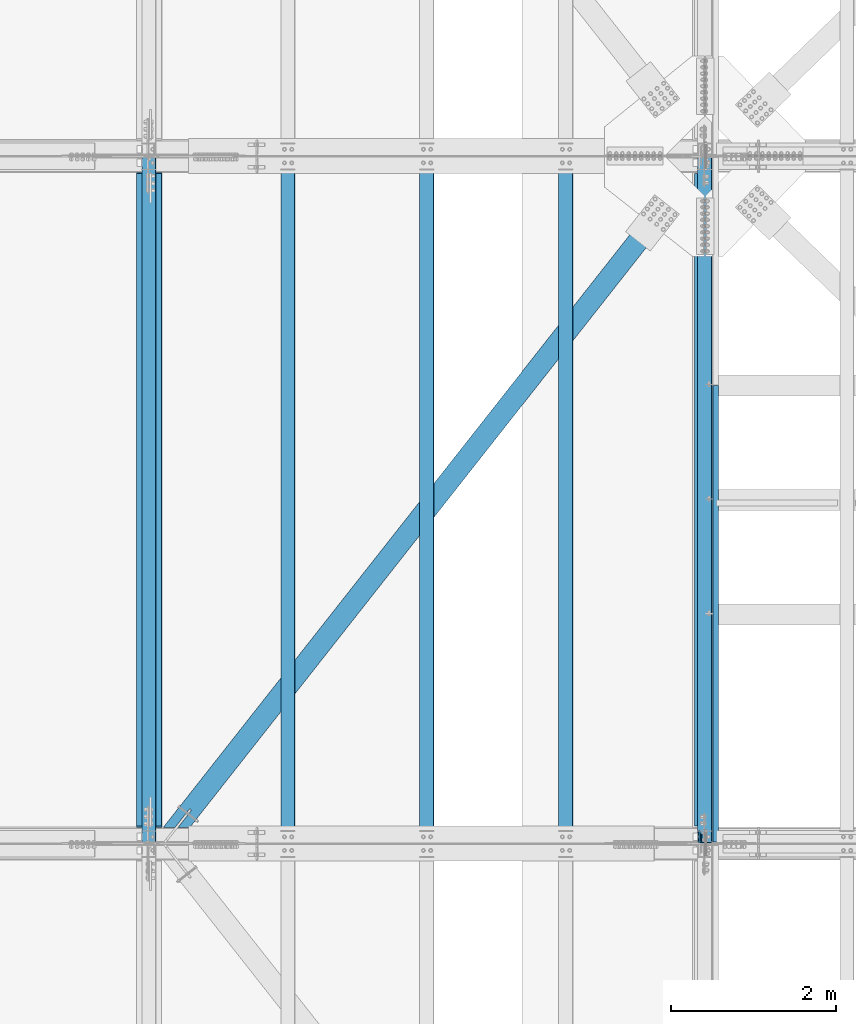
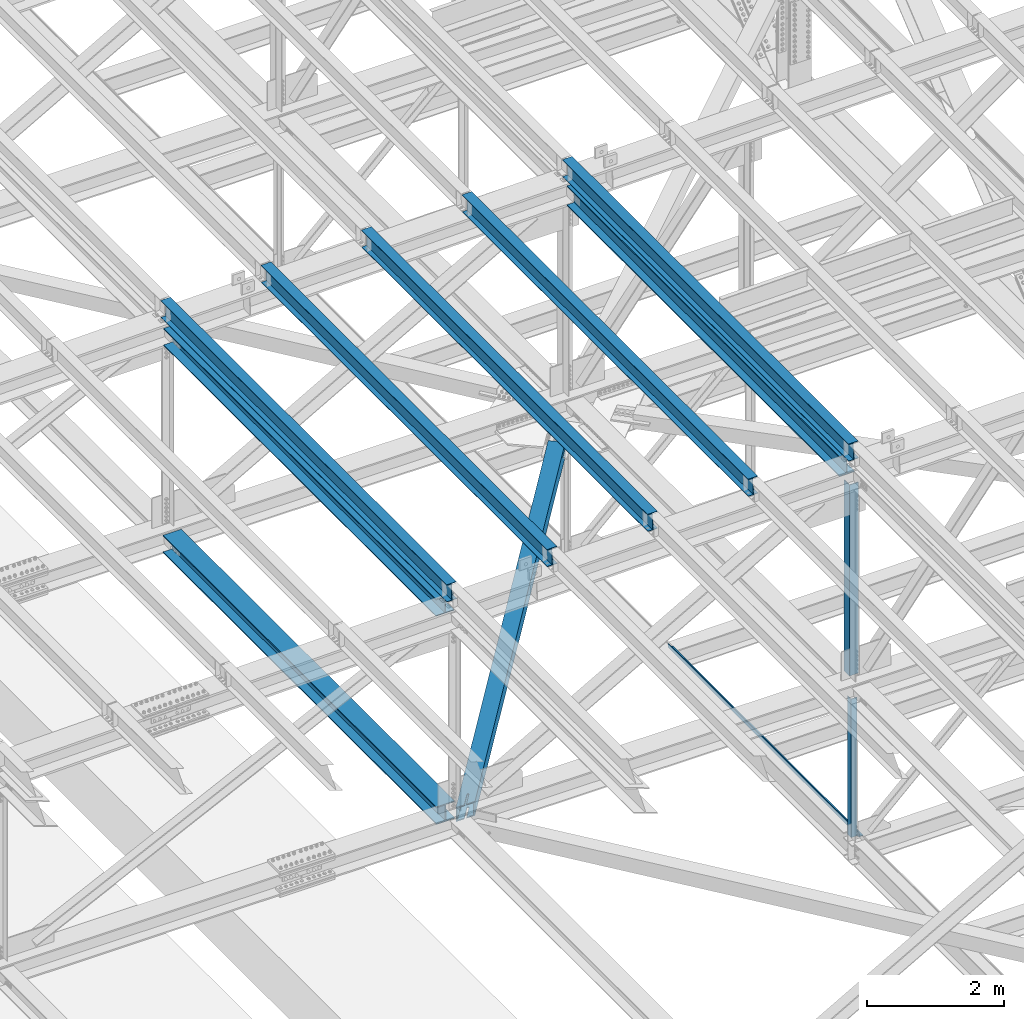
# One storey, part 1856 of 3843: 12 beams, 12 elements without a shape of their own.
"""IFC2X3 building model written with IfcOpenShell, lengths in millimetres."""

from ifc_helpers import new_model, si_unit, frame, origin_with_axes, place, context, subcontext, project, spatial, faceted_brep, material, type_object, element, aggregate, save


model = new_model("IFC2X3")

# Units and contexts
model_context = context("Model", 3, precision=1e-05, world=origin_with_axes())
body_context = subcontext(model_context, "Body", "Model", "MODEL_VIEW")
ifc_project = project(units=[si_unit("LENGTHUNIT", "METRE", prefix="MILLI"), si_unit("AREAUNIT", "SQUARE_METRE"), si_unit("VOLUMEUNIT", "CUBIC_METRE"), si_unit("MASSUNIT", "GRAM", prefix="KILO"), si_unit("TIMEUNIT", "SECOND"), si_unit("PLANEANGLEUNIT", "RADIAN"), si_unit("SOLIDANGLEUNIT", "STERADIAN"), si_unit("THERMODYNAMICTEMPERATUREUNIT", "DEGREE_CELSIUS"), si_unit("LUMINOUSINTENSITYUNIT", "LUMEN")], contexts=[model_context])

# Site, building, storey
site_placement = place(None, origin_with_axes())
site = spatial("IfcSite", under=ifc_project, at=site_placement, CompositionType="ELEMENT")
building_placement = place(site_placement, origin_with_axes())
building = spatial("IfcBuilding", under=site, at=building_placement, Name="Undefined", CompositionType="ELEMENT")
storey_placement = place(building_placement, origin_with_axes())
storey = spatial("IfcBuildingStorey", under=building, at=storey_placement, Name="Undefined", CompositionType="ELEMENT", Elevation=0.0)

# Assembly, beam
assembly_1_placement = place(storey_placement, origin_with_axes())
assembly_1 = element("IfcElementAssembly", 1, at=assembly_1_placement, inside=storey, Name="ANGLE", AssemblyPlace="NOTDEFINED", PredefinedType="RIGID_FRAME")
ifc_material_1 = material(Name="STEEL/A572-50")
beam_type_1 = type_object("IfcBeamType", Name="L4X4X3/8", PredefinedType="NOTDEFINED")
beam_1_placement = place(assembly_1_placement, frame((77012.7999999999, 50619.025, 42337.7414626822), z_axis=(0.0, 1.0, 0.0), x_axis=(0.0, 0.0, -1.0)))
beam_1 = element("IfcBeam", 2, at=beam_1_placement, type_object=beam_type_1, material=ifc_material_1, Name="ANGLE", ObjectType="L4X4X3/8", context=body_context, shape_type="Brep", body=[
    faceted_brep([(209.619479922985, 50.8000000000029, -50.8000000000029), (209.619479922985, 50.8000000000029, 50.8000000000029), (2671.51545346303, 50.8000000000029, 50.8000000000029), (2671.51545346303, 50.8000000000029, -50.8000000000029), (209.619479922985, 41.2749999999942, 50.8000000000029), (2671.51545346303, 41.2749999999942, 50.8000000000029), (209.619479922985, 41.2749999999942, -41.2750000000015), (2671.51545346303, 41.2749999999942, -41.2750000000015), (209.619479922985, -50.8000000000029, -41.2750000000015), (2671.51545346303, -50.8000000000029, -41.2750000000015), (209.619479922985, -50.8000000000029, -50.8000000000029), (2671.51545346303, -50.8000000000029, -50.8000000000029)], [[[0, 1, 2, 3]], [[1, 4, 5, 2]], [[4, 6, 7, 5]], [[6, 8, 9, 7]], [[8, 10, 11, 9]], [[10, 0, 3, 11]], [[5, 7, 9, 11, 3, 2]], [[10, 8, 6, 4, 1, 0]]]),
])
aggregate(assembly_1, [beam_1])

assembly_2_placement = place(storey_placement, origin_with_axes())
assembly_2 = element("IfcElementAssembly", 3, at=assembly_2_placement, inside=storey, Name="BEAM", AssemblyPlace="NOTDEFINED", PredefinedType="RIGID_FRAME")
ifc_material_2 = material(Name="STEEL/A992")
beam_type_2 = type_object("IfcBeamType", Name="W12X26", PredefinedType="NOTDEFINED")
beam_2_placement = place(assembly_2_placement, frame((77009.5092626681, 50558.6104205295, 46520.6173903341), z_axis=(-0.0211520975154853, -0.000575795999735418, 0.999776103550021), x_axis=(0.0, 0.999999834155183, 0.000575925000089143)))
beam_2 = element("IfcBeam", 4, at=beam_2_placement, type_object=beam_type_2, material=ifc_material_2, Name="BEAM", ObjectType="W12X26", context=body_context, shape_type="Brep", body=[
    faceted_brep([(12.6989964649474, 82.5499999998865, -155.574999999983), (12.7044809241561, 82.549999999901, -146.049999999967), (8343.90586255472, 82.5500000002794, -146.050000017567), (8343.90037809552, 82.5500000002648, -155.575000017569), (12.7054478725186, 3.17499999949359, -146.050000000199), (8343.90682950308, 3.17499999987194, -146.050000017793), (12.8736379546172, 3.17500000052678, 146.050000000163), (8344.07501958519, 3.17500000090513, 146.04999998257), (12.8726710062547, 82.5500000009342, 146.050000000396), (8344.07405263682, 82.5500000013126, 146.04999998281), (12.8781554654561, 82.5500000009633, 155.575000000412), (8344.07953709602, 82.5500000013417, 155.574999982811), (12.8801667180524, -82.549999999901, 155.574999999924), (8344.08154834861, -82.5499999995227, 155.574999982331), (12.874682258851, -82.5499999999302, 146.049999999916), (8344.07606388941, -82.5499999995518, 146.049999982315), (12.8737153104885, -3.17499999950815, 146.050000000148), (8344.07509694105, -3.17499999914435, 146.049999982555), (12.7055252283826, -3.17500000054133, -146.050000000221), (8343.90690685896, -3.17500000016298, -146.050000017814), (12.7064921767451, -82.5500000009488, -146.050000000454), (8343.90787380732, -82.5500000005704, -146.050000018047), (12.701007717551, -82.5500000009924, -155.575000000463), (8343.90238934811, -82.5500000006141, -155.575000018063)], [[[0, 1, 2, 3]], [[1, 4, 5, 2]], [[4, 6, 7, 5]], [[6, 8, 9, 7]], [[8, 10, 11, 9]], [[10, 12, 13, 11]], [[12, 14, 15, 13]], [[14, 16, 17, 15]], [[16, 18, 19, 17]], [[18, 20, 21, 19]], [[20, 22, 23, 21]], [[22, 0, 3, 23]], [[5, 7, 9, 11, 13, 15, 17, 19, 21, 23, 3, 2]], [[22, 20, 18, 16, 14, 12, 10, 8, 6, 4, 1, 0]]]),
])
aggregate(assembly_2, [beam_2])

assembly_3_placement = place(storey_placement, origin_with_axes())
assembly_3 = element("IfcElementAssembly", 5, at=assembly_3_placement, inside=storey, Name="BEAM", AssemblyPlace="NOTDEFINED", PredefinedType="RIGID_FRAME")
beam_3_placement = place(assembly_3_placement, frame((70253.109262286, 50558.6253514416, 46384.1035402932), z_axis=(-0.0211520984433592, -0.000479824000096415, 0.999776154196714), x_axis=(0.0, 0.999999884833111, 0.000479930999919957)))
beam_3 = element("IfcBeam", 6, at=beam_3_placement, type_object=beam_type_2, material=ifc_material_2, Name="BEAM", ObjectType="W12X26", context=body_context, shape_type="Brep", body=[
    faceted_brep([(12.6991634509395, 82.5499999998428, -155.574999999844), (12.7037337714428, 82.5499999998719, -146.049999999865), (8343.90469330046, 82.5500000003376, -146.050000022165), (8343.90012297995, 82.5500000002939, -155.575000022138), (12.7045395506648, 3.17499999943539, -146.049999999675), (8343.90549907969, 3.17499999990105, -146.050000021976), (12.8446960464062, 3.17500000059954, 146.049999999588), (8344.04565557543, 3.1750000010652, 146.049999977295), (12.8438902671915, 82.5500000010361, 146.049999999399), (8344.04484979621, 82.5500000015018, 146.049999977098), (12.848460587702, 82.5500000010943, 155.574999999371), (8344.04942011672, 82.5500000015454, 155.574999977071), (12.8501366084674, -82.5499999998428, 155.574999999772), (8344.05109613749, -82.5499999993917, 155.574999977478), (12.8455662879569, -82.5499999998719, 146.049999999792), (8344.04652581698, -82.5499999994208, 146.049999977491), (12.8447605087349, -3.17499999943539, 146.049999999603), (8344.04572003776, -3.17499999898428, 146.049999977302), (12.7046040130008, -3.17500000061409, -146.049999999661), (8343.90556354202, -3.17500000014843, -146.050000021954), (12.7054097922155, -82.5500000010506, -146.049999999464), (8343.90636932124, -82.550000000585, -146.050000021765), (12.700839471705, -82.5500000010798, -155.574999999444), (8343.90179900072, -82.5500000006141, -155.575000021745)], [[[0, 1, 2, 3]], [[1, 4, 5, 2]], [[4, 6, 7, 5]], [[6, 8, 9, 7]], [[8, 10, 11, 9]], [[10, 12, 13, 11]], [[12, 14, 15, 13]], [[14, 16, 17, 15]], [[16, 18, 19, 17]], [[18, 20, 21, 19]], [[20, 22, 23, 21]], [[22, 0, 3, 23]], [[5, 7, 9, 11, 13, 15, 17, 19, 21, 23, 3, 2]], [[22, 20, 18, 16, 14, 12, 10, 8, 6, 4, 1, 0]]]),
])
aggregate(assembly_3, [beam_3])

assembly_4_placement = place(storey_placement, origin_with_axes())
assembly_4 = element("IfcElementAssembly", 7, at=assembly_4_placement, inside=storey, Name="BEAM", AssemblyPlace="NOTDEFINED", PredefinedType="RIGID_FRAME")
beam_4_placement = place(assembly_4_placement, frame((75320.4092623759, 50558.6141531499, 46487.3437415612), z_axis=(-0.0211520982287039, -0.000551804000038829, 0.99977611706465), x_axis=(0.0, 0.999999847688282, 0.000551926999827809)))
beam_4 = element("IfcBeam", 8, at=beam_4_placement, type_object=beam_type_2, material=ifc_material_2, Name="BEAM", ObjectType="W12X26", context=body_context, shape_type="Brep", body=[
    faceted_brep([(12.6989964649474, 82.5499999998865, -155.574999999983), (12.7042941587642, 82.5499999994354, -146.049999999494), (8343.90556304539, 82.5499999997555, -146.050000014584), (8343.90030711613, 82.5499999996973, -155.575000014564), (12.7052208156529, 3.17499999899883, -146.049999999661), (8343.90648970228, 3.17499999931897, -146.050000014751), (12.8664026466795, 3.1750000010361, 146.049999999603), (8344.06767153331, 3.17500000135624, 146.049999984512), (12.8654759897909, 82.5500000014581, 146.049999999777), (8344.06674487643, 82.5500000017782, 146.049999984687), (12.8707319190653, 82.5500000015309, 155.57499999975), (8344.0720008057, 82.550000001851, 155.574999984659), (12.8726593653919, -82.5499999993626, 155.574999999408), (8344.07392825203, -82.5499999990425, 155.574999984317), (12.8674034361175, -82.5499999994354, 146.049999999435), (8344.06867232276, -82.5499999991298, 146.04999998433), (12.8664767792361, -3.17499999899883, 146.049999999595), (8344.06774566587, -3.17499999869324, 146.049999984505), (12.7052949482022, -3.17500000102154, -146.049999999675), (8343.90656383483, -3.1750000007014, -146.050000014773), (12.7062216050908, -82.5500000014581, -146.049999999836), (8343.90749049172, -82.550000001138, -146.050000014926), (12.701007717551, -82.5500000009924, -155.575000000463), (8343.90223456245, -82.5500000011962, -155.575000014913)], [[[0, 1, 2, 3]], [[1, 4, 5, 2]], [[4, 6, 7, 5]], [[6, 8, 9, 7]], [[8, 10, 11, 9]], [[10, 12, 13, 11]], [[12, 14, 15, 13]], [[14, 16, 17, 15]], [[16, 18, 19, 17]], [[18, 20, 21, 19]], [[20, 22, 23, 21]], [[22, 0, 3, 23]], [[5, 7, 9, 11, 13, 15, 17, 19, 21, 23, 3, 2]], [[22, 20, 18, 16, 14, 12, 10, 8, 6, 4, 1, 0]]]),
])
aggregate(assembly_4, [beam_4])

assembly_5_placement = place(storey_placement, origin_with_axes())
assembly_5 = element("IfcElementAssembly", 9, at=assembly_5_placement, inside=storey, Name="BEAM", AssemblyPlace="NOTDEFINED", PredefinedType="RIGID_FRAME")
beam_5_placement = place(assembly_5_placement, frame((73631.3092622969, 50558.6178858741, 46453.5190195992), z_axis=(-0.0211520979550987, -0.000527811000014481, 0.99977613002494), x_axis=(0.0, 0.999999860645476, 0.000527928999812938)))
beam_5 = element("IfcBeam", 10, at=beam_5_placement, type_object=beam_type_2, material=ifc_material_2, Name="BEAM", ObjectType="W12X26", context=body_context, shape_type="Brep", body=[
    faceted_brep([(12.6990798975457, 82.5500000015018, -155.575000000346), (12.7041072968932, 82.550000001429, -146.05000000033), (8343.90526825596, 82.55000000172, -146.05000001497), (8343.9002408566, 82.5500000018073, -155.575000014986), (12.7049936623152, 3.17500000099244, -146.050000000228), (8343.90615462136, 3.17500000129803, -146.050000014875), (12.8591672426046, 3.17499999901338, 146.050000000178), (8344.06032820167, 3.17499999931897, 146.049999985538), (12.8582808771971, 82.5499999994499, 146.050000000076), (8344.05944183625, 82.5499999997555, 146.049999985429), (12.8633082765518, 82.5499999993917, 155.575000000092), (8344.06446923561, 82.5499999996973, 155.574999985445), (12.8651519166087, -82.5500000015163, 155.575000000303), (8344.06631287567, -82.5500000012253, 155.574999985656), (12.860124517254, -82.5500000014435, 146.050000000294), (8344.06128547631, -82.550000001138, 146.049999985647), (12.8592381518392, -3.17500000102154, 146.050000000185), (8344.0603991109, -3.17500000071595, 146.049999985546), (12.7050645715426, -3.17499999904248, -146.050000000214), (8343.9062255306, -3.17499999873689, -146.05000001486), (12.7059509369574, -82.549999999479, -146.050000000112), (8343.90711189601, -82.5499999991735, -146.050000014766), (12.7009235375954, -82.5499999994208, -155.575000000128), (8343.90208449666, -82.5499999991152, -155.575000014775)], [[[0, 1, 2, 3]], [[1, 4, 5, 2]], [[4, 6, 7, 5]], [[6, 8, 9, 7]], [[8, 10, 11, 9]], [[10, 12, 13, 11]], [[12, 14, 15, 13]], [[14, 16, 17, 15]], [[16, 18, 19, 17]], [[18, 20, 21, 19]], [[20, 22, 23, 21]], [[22, 0, 3, 23]], [[5, 7, 9, 11, 13, 15, 17, 19, 21, 23, 3, 2]], [[22, 20, 18, 16, 14, 12, 10, 8, 6, 4, 1, 0]]]),
])
aggregate(assembly_5, [beam_5])

assembly_6_placement = place(storey_placement, origin_with_axes())
assembly_6 = element("IfcElementAssembly", 11, at=assembly_6_placement, inside=storey, Name="BEAM", AssemblyPlace="NOTDEFINED", PredefinedType="RIGID_FRAME")
beam_6_placement = place(assembly_6_placement, frame((71942.2092622902, 50558.6216186291, 46419.0731397891), z_axis=(-0.0211520976931496, -0.000503817000200796, 0.999776142409695), x_axis=(0.0, 0.99999987302727, 0.000503930000014023)))
beam_6 = element("IfcBeam", 12, at=beam_6_placement, type_object=beam_type_2, material=ifc_material_2, Name="BEAM", ObjectType="W12X26", context=body_context, shape_type="Brep", body=[
    faceted_brep([(12.6991634509395, 82.5499999998428, -155.574999999844), (12.7039557644093, 82.5499999995955, -146.050000000265), (8343.90497839348, 82.5500000002648, -146.049999989293), (8343.90019070176, 82.5499999997992, -155.575000011893), (12.7048094305574, 3.1749999991589, -146.050000000512), (8343.90582446579, 3.17499999981374, -146.049999989249), (12.8519316705861, 3.17499999998836, 146.049999999879), (8344.05298950585, 3.17499999975553, 146.05000001048), (12.8510855982677, 82.5500000004395, 146.049999999828), (8344.05214343353, 82.5500000002066, 146.050000010437), (12.8558844582731, 82.5500000004249, 155.57499999983), (8344.05694229354, 82.5500000001921, 155.575000010424), (12.8576442886988, -82.5500000004977, 155.574999999917), (8344.05870212396, -82.5500000007305, 155.575000010518), (12.8528454286934, -82.5500000004977, 146.04999999993), (8344.05390326396, -82.550000000716, 146.050000010531), (12.851999356375, -3.17500000004657, 146.049999999886), (8344.05305719164, -3.17500000026484, 146.05000001048), (12.7048777238451, -3.17500000087603, -146.050000000534), (8343.90589215158, -3.17500000023574, -146.049999989242), (12.7056803886298, -82.5500000004395, -146.049999999799), (8343.90673822389, -82.5500000006723, -146.049999989205), (12.700839471705, -82.5500000010798, -155.574999999444), (8343.90196632734, -82.5500000011089, -155.575000012395)], [[[0, 1, 2, 3]], [[1, 4, 5, 2]], [[4, 6, 7, 5]], [[6, 8, 9, 7]], [[8, 10, 11, 9]], [[10, 12, 13, 11]], [[12, 14, 15, 13]], [[14, 16, 17, 15]], [[16, 18, 19, 17]], [[18, 20, 21, 19]], [[20, 22, 23, 21]], [[22, 0, 3, 23]], [[5, 7, 9, 11, 13, 15, 17, 19, 21, 23, 3, 2]], [[22, 20, 18, 16, 14, 12, 10, 8, 6, 4, 1, 0]]]),
])
aggregate(assembly_6, [beam_6])

assembly_7_placement = place(storey_placement, origin_with_axes())
assembly_7 = element("IfcElementAssembly", 13, at=assembly_7_placement, inside=storey, Name="BENT_PLATE", AssemblyPlace="NOTDEFINED", PredefinedType="RIGID_FRAME")
ifc_material_3 = material(Name="STEEL/A36")
beam_type_3 = type_object("IfcBeamType", PredefinedType="NOTDEFINED")
beam_7_placement = place(assembly_7_placement, frame((77179.4875000007, 53353.49375, 39627.1749999995), z_axis=(0.0, 1.0, 0.0), x_axis=(-1.0, 0.0, 0.0)))
beam_7 = element("IfcBeam", 14, at=beam_7_placement, type_object=beam_type_3, material=ifc_material_3, Name="BENT_PLATE", context=body_context, shape_type="Brep", body=[
    faceted_brep([(0.0, -3.17500000000291, -2776.53750000001), (0.0, -3.17500000000291, 2776.53750000001), (0.0, 3.17500000000291, 2776.53750000001), (0.0, 3.17500000000291, -2776.53750000001), (69.8500000010827, 3.17500000000291, 2776.53750000001), (69.8500000010827, 3.17500000000291, -2776.53750000001), (76.2000000010739, -3.17500000000291, -2776.53750000001), (76.2000000010739, -3.17500000000291, 2776.53750000001), (69.8500000011554, 73.0249999989392, 2776.53750000001), (69.8500000011554, 73.0249999989392, -2776.53750000001), (76.2000000011612, 73.0249999989246, 2776.53750000001), (76.2000000011612, 73.0249999989246, -2776.53750000001)], [[[0, 1, 2, 3]], [[3, 2, 4, 5]], [[1, 0, 6, 7]], [[5, 4, 8, 9]], [[4, 2, 1, 7, 10, 8]], [[7, 6, 11, 10]], [[6, 0, 3, 5, 9, 11]], [[10, 11, 9, 8]]]),
])
aggregate(assembly_7, [beam_7])

assembly_8_placement = place(storey_placement, origin_with_axes())
assembly_8 = element("IfcElementAssembly", 15, at=assembly_8_placement, inside=storey, Name="BEAM", AssemblyPlace="NOTDEFINED", PredefinedType="RIGID_FRAME")
beam_type_4 = type_object("IfcBeamType", Name="W12X79", PredefinedType="NOTDEFINED")
beam_8_placement = place(assembly_8_placement, frame((70256.4, 50558.7, 42344.128873093), z_axis=(0.0, -0.000478386999799112, 0.999999885572933), x_axis=(-9.99999573355848e-10, 0.999999885572933, 0.000478386999795731)))
beam_8 = element("IfcBeam", 16, at=beam_8_placement, type_object=beam_type_4, material=ifc_material_2, Name="BEAM", ObjectType="W12X79", context=body_context, shape_type="Brep", body=[
    faceted_brep([(198.362335344144, 153.987500000818, -157.162499999053), (198.37144861753, 153.987500000803, -138.112499999093), (8158.09736240654, 153.987500033312, -138.112499976291), (8158.08824913316, 153.987500033312, -157.162499976257), (198.371448468824, 6.35000000080618, -138.112499999166), (8158.09736225783, 6.3500000333006, -138.112499976356), (198.50359093296, 6.35000000080618, 138.112500000309), (8158.22950472197, 6.3500000333006, 138.112500023104), (198.503591081673, 153.987500000818, 138.112500000381), (8158.22950487068, 153.987500033312, 138.112500023177), (198.51270435506, 153.987500000818, 157.162500000348), (8158.23861814407, 153.987500033312, 157.162500023143), (198.512704044842, -153.987499999173, 157.16250000021), (8158.23861783386, -153.987499966679, 157.162500022998), (198.503590771455, -153.987499999188, 138.112500000243), (8158.22950456046, -153.987499966694, 138.112500023031), (198.503590920169, -6.34999999919091, 138.112500000301), (8158.22950470918, -6.34999996669649, 138.112500023104), (198.371448456026, -6.34999999919091, -138.112499999166), (8158.09736224504, -6.34999996669649, -138.112499976363), (198.371448307313, -153.987499999188, -138.112499999232), (8158.09736209633, -153.987499966694, -138.112499976436), (198.362335033926, -153.987499999188, -157.162499999191), (8158.08824882294, -153.987499966694, -157.162499976403)], [[[0, 1, 2, 3]], [[1, 4, 5, 2]], [[4, 6, 7, 5]], [[6, 8, 9, 7]], [[8, 10, 11, 9]], [[10, 12, 13, 11]], [[12, 14, 15, 13]], [[14, 16, 17, 15]], [[16, 18, 19, 17]], [[18, 20, 21, 19]], [[20, 22, 23, 21]], [[22, 0, 3, 23]], [[5, 7, 9, 11, 13, 15, 17, 19, 21, 23, 3, 2]], [[22, 20, 18, 16, 14, 12, 10, 8, 6, 4, 1, 0]]]),
])
aggregate(assembly_8, [beam_8])

assembly_9_placement = place(storey_placement, origin_with_axes())
assembly_9 = element("IfcElementAssembly", 17, at=assembly_9_placement, inside=storey, Name="ANGLE", AssemblyPlace="NOTDEFINED", PredefinedType="RIGID_FRAME")
beam_type_5 = type_object("IfcBeamType", Name="L6X6X1/2", PredefinedType="NOTDEFINED")
beam_9_placement = place(assembly_9_placement, frame((77012.7999988756, 50644.425, 46168.1896257459), z_axis=(0.0, 1.0, 0.0), x_axis=(0.0, 0.0, -1.0)))
beam_9 = element("IfcBeam", 18, at=beam_9_placement, type_object=beam_type_5, material=ifc_material_1, Name="ANGLE", ObjectType="L6X6X1/2", context=body_context, shape_type="Brep", body=[
    faceted_brep([(224.004017926003, 76.1999999999971, -76.1999999999971), (224.004017926003, 76.1999999999971, 76.1999999999971), (3620.06358220964, 76.1999999999971, 76.1999999999971), (3620.06358220964, 76.1999999999971, -76.1999999999971), (224.004017926003, 63.5, 76.1999999999971), (3620.06358220964, 63.5, 76.1999999999971), (224.004017926003, 63.5, -63.5), (3620.06358220964, 63.5, -63.5), (224.004017926003, -76.1999999999971, -63.5), (3620.06358220964, -76.1999999999971, -63.5), (224.004017926003, -76.1999999999971, -76.1999999999971), (3620.06358220964, -76.1999999999971, -76.1999999999971)], [[[0, 1, 2, 3]], [[1, 4, 5, 2]], [[4, 6, 7, 5]], [[6, 8, 9, 7]], [[8, 10, 11, 9]], [[10, 0, 3, 11]], [[5, 7, 9, 11, 3, 2]], [[10, 8, 6, 4, 1, 0]]]),
])
aggregate(assembly_9, [beam_9])

assembly_10_placement = place(storey_placement, origin_with_axes())
assembly_10 = element("IfcElementAssembly", 19, at=assembly_10_placement, inside=storey, AssemblyPlace="NOTDEFINED", PredefinedType="RIGID_FRAME")
ifc_material_4 = material()
beam_type_6 = type_object("IfcBeamType", Name="HSS10X10X3/4", PredefinedType="NOTDEFINED")
beam_10_placement = place(assembly_10_placement, frame((70434.2000000667, 50558.6999998931, 42246.55), z_axis=(-0.785737878354052, 0.618559606278711, 0.0), x_axis=(0.618559606278724, 0.785737878354041, 0.0)))
beam_10 = element("IfcBeam", 20, at=beam_10_placement, type_object=beam_type_6, material=ifc_material_4, ObjectType="HSS10X10X3/4", context=body_context, shape_type="Brep", body=[
    faceted_brep([(241.30162407973, -127.0, 14.2875006095273), (241.30162407973, -107.949999999997, 14.2875006095273), (516.209344809561, -107.949999999997, 14.2875004909001), (516.209344809561, -127.0, 14.2875004909001), (521.676934495421, -107.949999999997, 13.1999292826367), (521.676934495421, -127.0, 13.1999292826367), (526.312133215446, -107.949999999997, 10.1027885154035), (526.312133215446, -127.0, 10.1027885154035), (529.409273982694, -107.949999999997, 5.46758979538572), (529.409273982694, -127.0, 5.46758979538572), (516.209344809772, -127.0, -14.2874995075981), (516.209344809772, -107.949999999997, -14.2874995075981), (263.79683683475, -107.949999999997, -14.2874993808655), (263.79683683475, -127.0, -14.2874993808655), (521.676934495611, -127.0, -13.1999282993202), (521.676934495611, -107.949999999997, -13.1999282993202), (526.312133215585, -127.0, -10.1027875320869), (526.312133215585, -107.949999999997, -10.1027875320869), (529.40927398276, -127.0, -5.4675888120546), (529.40927398276, -107.949999999997, -5.4675888120546), (530.496845191009, -127.0, 1.09503162093461e-07), (530.496845191009, -107.949999999997, 1.09503162093461e-07), (241.30162407973, 107.949999999997, 14.2875006095273), (241.30162407973, 127.0, 14.2875006095273), (516.209344809561, 127.0, 14.2875004909001), (516.209344809561, 107.949999999997, 14.2875004909001), (521.676934495421, 127.0, 13.1999292826367), (521.676934495421, 107.949999999997, 13.1999292826367), (526.312133215446, 127.0, 10.1027885154035), (526.312133215446, 107.949999999997, 10.1027885154035), (529.409273982694, 127.0, 5.46758979538572), (529.409273982694, 107.949999999997, 5.46758979538572), (516.209344809772, 107.949999999997, -14.2874995075981), (516.209344809772, 127.0, -14.2874995075981), (263.79683683475, 127.0, -14.2874993808655), (263.79683683475, 107.949999999997, -14.2874993808655), (521.676934495611, 107.949999999997, -13.1999282993202), (521.676934495611, 127.0, -13.1999282993202), (526.312133215585, 107.949999999997, -10.1027875320869), (526.312133215585, 127.0, -10.1027875320869), (529.40927398276, 107.949999999997, -5.4675888120546), (529.40927398276, 127.0, -5.4675888120546), (530.496845191009, 107.949999999997, 1.09503162093461e-07), (530.496845191009, 127.0, 1.09503162093461e-07), (9570.41327467293, -26.9869995121117, -107.949999957629), (9570.4132746846, -26.9869995121117, -126.999999957603), (9317.00267859534, -26.9869995121117, -126.999999958709), (9317.00267858371, -26.9869995121117, -107.94999995875), (9311.5350889095, -25.8994283038264, -126.999999958745), (9311.53508889789, -25.8994283038264, -107.949999958772), (9306.89989018952, -22.8022875365859, -126.999999958767), (9306.89989017788, -22.8022875365859, -107.949999958793), (9303.80274942231, -18.167088816539, -126.999999958774), (9303.80274941069, -18.167088816539, -107.949999958815), (9302.71517821404, -12.6994991306419, -126.999999958782), (9302.71517820242, -12.6994991306419, -107.949999958808), (9303.80274942231, -7.23191020768718, -126.999999958774), (9303.80274941069, -7.23191020768718, -107.949999958815), (9306.89989018952, -2.59671148764028, -126.999999958767), (9306.89989017788, -2.59671148764028, -107.949999958793), (9311.5350889095, 0.500429279600212, -126.999999958745), (9311.53508889789, 0.500429279600212, -107.949999958772), (9317.00267859534, 1.58800048788544, -126.999999958709), (9317.00267858371, 1.58800048788544, -107.94999995875), (9570.41327467293, 1.58800048788544, -107.949999957629), (9570.4132746846, 1.58800048788544, -126.999999957603), (9570.41327454061, 107.949999999997, 107.950000042016), (9570.41327467293, 107.949999999997, -107.949999957629), (9570.4132746846, 127.0, -126.999999957603), (9570.41327452892, 127.0, 127.000000041982), (9570.41327452892, 1.58800048788544, 127.000000041982), (9570.41327454061, 1.58800048788544, 107.950000042016), (9570.41327467293, -107.949999999997, -107.949999957629), (337.531145820481, 107.949999999997, -107.949999998335), (337.531145820481, -107.949999999997, -107.949999998335), (167.567316059503, -107.949999999997, 107.950000000557), (9570.41327454061, -107.949999999997, 107.950000042016), (9317.002678452, 1.58800048788544, 107.950000040895), (9311.53508876616, 0.500429279600212, 107.950000040866), (9306.89989004617, -2.59671148764028, 107.950000040852), (9303.80274927898, -7.23191020768718, 107.950000040837), (9302.71517807071, -12.6994991306419, 107.95000004083), (9303.80274927898, -18.167088816539, 107.950000040837), (9306.89989004617, -22.8022875365859, 107.950000040852), (9311.53508876616, -25.8994283038264, 107.950000040866), (9317.002678452, -26.9869995121117, 107.950000040895), (9570.41327454061, -26.9869995121117, 107.950000042016), (167.567316059503, 107.949999999997, 107.950000000557), (9317.00267844039, 1.58800048788544, 127.000000040855), (9311.53508875455, 0.500429279600212, 127.00000004084), (9306.89989003456, -2.59671148764028, 127.000000040811), (9303.80274926734, -7.23191020768718, 127.000000040811), (9302.71517805908, -12.6994991306419, 127.000000040796), (9303.80274926734, -18.167088816539, 127.000000040811), (9306.89989003456, -22.8022875365859, 127.000000040811), (9311.53508875455, -25.8994283038264, 127.00000004084), (9317.00267844039, -26.9869995121117, 127.000000040855), (9570.41327452892, -26.9869995121117, 127.000000041982), (9570.41327452892, -127.0, 127.000000041982), (9570.4132746846, -127.0, -126.999999957603), (352.527954328805, -127.0, -126.999999998239), (352.527954328805, 127.0, -126.999999998239), (152.57050755118, 127.0, 127.000000000466), (152.57050755118, -127.0, 127.000000000466)], [[[0, 1, 2, 3]], [[3, 2, 4, 5]], [[5, 4, 6, 7]], [[7, 6, 8, 9]], [[10, 11, 12, 13]], [[14, 15, 11, 10]], [[16, 17, 15, 14]], [[18, 19, 17, 16]], [[20, 21, 19, 18]], [[9, 8, 21, 20]], [[22, 23, 24, 25]], [[25, 24, 26, 27]], [[27, 26, 28, 29]], [[29, 28, 30, 31]], [[32, 33, 34, 35]], [[36, 37, 33, 32]], [[38, 39, 37, 36]], [[40, 41, 39, 38]], [[42, 43, 41, 40]], [[31, 30, 43, 42]], [[44, 45, 46, 47]], [[47, 46, 48, 49]], [[49, 48, 50, 51]], [[51, 50, 52, 53]], [[53, 52, 54, 55]], [[55, 54, 56, 57]], [[57, 56, 58, 59]], [[59, 58, 60, 61]], [[61, 60, 62, 63]], [[64, 63, 62, 65]], [[66, 67, 64, 65, 68, 69, 70, 71]], [[72, 44, 47, 49, 51, 53, 55, 57, 59, 61, 63, 64, 67, 73, 74]], [[6, 4, 2, 1, 75, 76, 72, 74, 12, 11, 15, 17, 19, 21, 8]], [[66, 71, 77, 78, 79, 80, 81, 82, 83, 84, 85, 86, 76, 75, 87]], [[70, 88, 77, 71]], [[89, 78, 77, 88]], [[90, 79, 78, 89]], [[91, 80, 79, 90]], [[92, 81, 80, 91]], [[93, 82, 81, 92]], [[94, 83, 82, 93]], [[95, 84, 83, 94]], [[96, 85, 84, 95]], [[97, 86, 85, 96]], [[98, 99, 45, 44, 72, 76, 86, 97]], [[68, 65, 62, 60, 58, 56, 54, 52, 50, 48, 46, 45, 99, 100, 101]], [[74, 73, 35, 34, 101, 100, 13, 12]], [[28, 26, 24, 23, 102, 69, 68, 101, 34, 33, 37, 39, 41, 43, 30]], [[98, 97, 96, 95, 94, 93, 92, 91, 90, 89, 88, 70, 69, 102, 103]], [[16, 14, 10, 13, 100, 99, 98, 103, 0, 3, 5, 7, 9, 20, 18]], [[103, 102, 23, 22, 87, 75, 1, 0]], [[38, 36, 32, 35, 73, 67, 66, 87, 22, 25, 27, 29, 31, 42, 40]]]),
])
aggregate(assembly_10, [beam_10])

assembly_11_placement = place(storey_placement, origin_with_axes())
assembly_11 = element("IfcElementAssembly", 21, at=assembly_11_placement, inside=storey, Name="BEAM", AssemblyPlace="NOTDEFINED", PredefinedType="RIGID_FRAME")
beam_type_7 = type_object("IfcBeamType", Name="W14X68", PredefinedType="NOTDEFINED")
beam_11_placement = place(assembly_11_placement, frame((77012.8, 50558.7000000011, 46168.1891609689), z_axis=(0.0, -0.000575925000091956, 0.999999834155183), x_axis=(0.0, 0.999999834155183, 0.000575925000089143)))
beam_11 = element("IfcBeam", 22, at=beam_11_placement, type_object=beam_type_7, material=ifc_material_2, Name="BEAM", ObjectType="W14X68", context=body_context, shape_type="Brep", body=[
    faceted_brep([(212.62263579484, 127.0, -177.799999999857), (212.633607167911, 127.0, -158.74999999992), (8143.78492245491, 127.0, -158.750000016676), (8143.77395108184, 127.0, -177.800000016621), (212.633607167911, 5.55624999999418, -158.74999999992), (8143.78492245491, 5.55624999999418, -158.750000016676), (212.816463385774, 5.55624999999418, 158.749999999003), (8143.96777867276, 5.55624999999418, 158.749999982254), (212.816463385774, 127.0, 158.749999999003), (8143.96777867276, 127.0, 158.749999982254), (212.827434758845, 127.0, 177.799999998941), (8143.97875004583, 127.0, 177.799999982184), (212.827434758845, -127.0, 177.799999998941), (8143.97875004583, -127.0, 177.799999982184), (212.816463385774, -127.0, 158.749999999003), (8143.96777867276, -127.0, 158.749999982254), (212.816463385774, -5.55624999999418, 158.749999999003), (8143.96777867276, -5.55624999999418, 158.749999982254), (212.633607167911, -5.55624999999418, -158.74999999992), (8143.78492245491, -5.55624999999418, -158.750000016676), (212.633607167911, -127.0, -158.74999999992), (8143.78492245491, -127.0, -158.750000016676), (212.62263579484, -127.0, -177.799999999857), (8143.77395108184, -127.0, -177.800000016621)], [[[0, 1, 2, 3]], [[1, 4, 5, 2]], [[4, 6, 7, 5]], [[6, 8, 9, 7]], [[8, 10, 11, 9]], [[10, 12, 13, 11]], [[12, 14, 15, 13]], [[14, 16, 17, 15]], [[16, 18, 19, 17]], [[18, 20, 21, 19]], [[20, 22, 23, 21]], [[22, 0, 3, 23]], [[5, 7, 9, 11, 13, 15, 17, 19, 21, 23, 3, 2]], [[22, 20, 18, 16, 14, 12, 10, 8, 6, 4, 1, 0]]]),
])
aggregate(assembly_11, [beam_11])

assembly_12_placement = place(storey_placement, origin_with_axes())
assembly_12 = element("IfcElementAssembly", 23, at=assembly_12_placement, inside=storey, Name="BEAM", AssemblyPlace="NOTDEFINED", PredefinedType="RIGID_FRAME")
beam_type_8 = type_object("IfcBeamType", Name="W12X65", PredefinedType="NOTDEFINED")
beam_12_placement = place(assembly_12_placement, frame((70256.4, 50558.7000000003, 46031.6711817704), z_axis=(0.0, -0.000479930999921636, 0.999999884833111), x_axis=(0.0, 0.999999884833111, 0.000479930999919957)))
beam_12 = element("IfcBeam", 24, at=beam_12_placement, type_object=beam_type_8, material=ifc_material_2, Name="BEAM", ObjectType="W12X65", context=body_context, shape_type="Brep", body=[
    faceted_brep([(212.651121116556, 152.399999999994, -153.987500001029), (212.65874002206, 152.399999999994, -138.112500000978), (8143.8096534761, 152.399999999994, -138.112500022209), (8143.8020345706, 152.399999999994, -153.98750002226), (212.65874002206, 4.76249999999709, -138.112500000978), (8143.8096534761, 4.76249999999709, -138.112500022209), (212.791308977779, 4.76249999999709, 138.112499999857), (8143.94222243182, 4.76249999999709, 138.112499978626), (212.791308977779, 152.399999999994, 138.112499999857), (8143.94222243182, 152.399999999994, 138.112499978626), (212.798927883283, 152.399999999994, 153.987499999901), (8143.94984133732, 152.399999999994, 153.987499978677), (212.798927883283, -152.399999999994, 153.987499999901), (8143.94984133732, -152.399999999994, 153.987499978677), (212.791308977779, -152.399999999994, 138.112499999857), (8143.94222243182, -152.399999999994, 138.112499978626), (212.791308977779, -4.76249999999709, 138.112499999857), (8143.94222243182, -4.76249999999709, 138.112499978626), (212.65874002206, -4.76249999999709, -138.112500000978), (8143.8096534761, -4.76249999999709, -138.112500022209), (212.65874002206, -152.399999999994, -138.112500000978), (8143.8096534761, -152.399999999994, -138.112500022209), (212.651121116556, -152.399999999994, -153.987500001029), (8143.8020345706, -152.399999999994, -153.98750002226)], [[[0, 1, 2, 3]], [[1, 4, 5, 2]], [[4, 6, 7, 5]], [[6, 8, 9, 7]], [[8, 10, 11, 9]], [[10, 12, 13, 11]], [[12, 14, 15, 13]], [[14, 16, 17, 15]], [[16, 18, 19, 17]], [[18, 20, 21, 19]], [[20, 22, 23, 21]], [[22, 0, 3, 23]], [[5, 7, 9, 11, 13, 15, 17, 19, 21, 23, 3, 2]], [[22, 20, 18, 16, 14, 12, 10, 8, 6, 4, 1, 0]]]),
])
aggregate(assembly_12, [beam_12])

save(model, "model.ifc")
